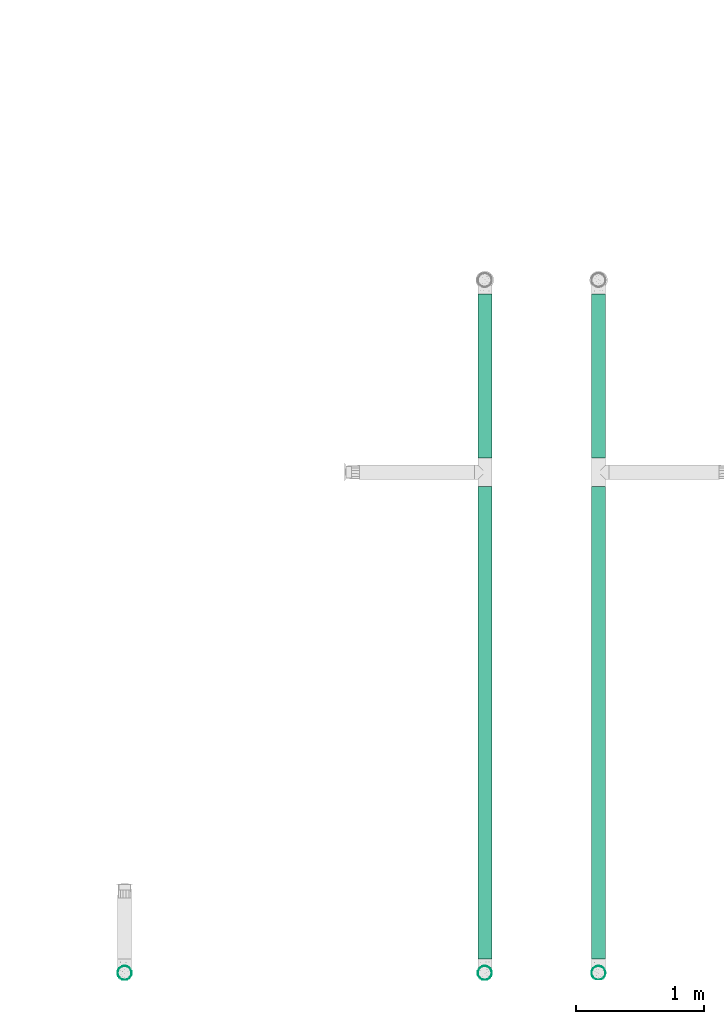
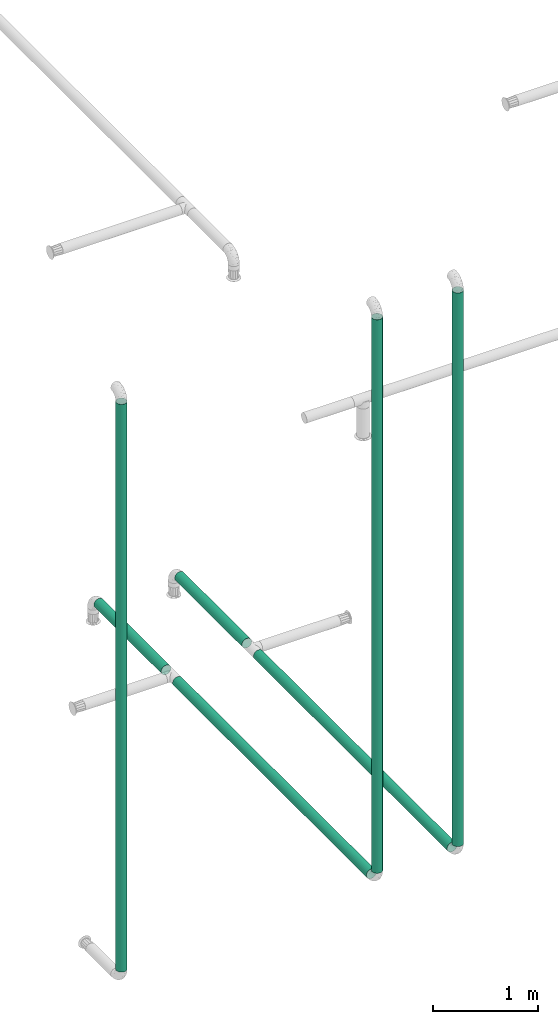
# One storey, part 1 of 123: 7 flow segments.
"""IFC2X3 building model written with IfcOpenShell, lengths in millimetres."""

from ifc_helpers import new_model, entity, si_unit, converted_unit, derived_unit, direction, frame, origin_with_axes, origin_2d_with_axis, place, context, subcontext, project, spatial, hollow_circle, extrude, source, transform, mapped, material, layer, layer_set, layer_usage, type_object, element, save


model = new_model("IFC2X3")

# Units and contexts
model_context = context("Model", 3, precision=1e-05, world=origin_with_axes(), true_north=direction((0.0, 1.0)))
body_context = subcontext(model_context, "Body", "Model", "MODEL_VIEW")
ifc_project = project(units=[si_unit("AREAUNIT", "SQUARE_METRE"), si_unit("VOLUMEUNIT", "CUBIC_METRE", prefix="DECI"), si_unit("TIMEUNIT", "SECOND"), si_unit("THERMODYNAMICTEMPERATUREUNIT", "DEGREE_CELSIUS"), si_unit("PRESSUREUNIT", "PASCAL"), si_unit("MASSUNIT", "GRAM", prefix="KILO"), si_unit("LENGTHUNIT", "METRE", prefix="MILLI"), si_unit("POWERUNIT", "WATT"), si_unit("ELECTRICCURRENTUNIT", "AMPERE"), si_unit("ELECTRICVOLTAGEUNIT", "VOLT"), derived_unit("VOLUMETRICFLOWRATEUNIT", [(si_unit("VOLUMEUNIT", "CUBIC_METRE", prefix="DECI"), 1), (si_unit("TIMEUNIT", "SECOND"), -1)]), derived_unit("LINEARVELOCITYUNIT", [(si_unit("LENGTHUNIT", "METRE"), 1), (si_unit("TIMEUNIT", "SECOND"), -1)]), derived_unit("MASSDENSITYUNIT", [(si_unit("MASSUNIT", "GRAM", prefix="KILO"), 1), (si_unit("VOLUMEUNIT", "CUBIC_METRE"), -1)]), converted_unit("PLANEANGLEUNIT", "DEGREE", entity("IfcRatioMeasure", 0.01745), si_unit("PLANEANGLEUNIT", "RADIAN"), dimensions=[0, 0, 0, 0, 0, 0, 0])], contexts=[model_context])

# Site, building, storey
site_placement = place(None, origin_with_axes())
site = spatial("IfcSite", under=ifc_project, at=site_placement, CompositionType="ELEMENT")
building_placement = place(site_placement, origin_with_axes())
building = spatial("IfcBuilding", under=site, at=building_placement, Name="mc-building", CompositionType="ELEMENT")
storey_placement = place(building_placement, origin_with_axes())
storey = spatial("IfcBuildingStorey", under=building, at=storey_placement, Name="1. Korrus", CompositionType="ELEMENT", Elevation=0.0)

# Flow segments
ifc_material = material(Name="FZ1")
ifc_layer = layer(ifc_material, 0.0)
ifc_layer_set = layer_set([ifc_layer], Name="FZ1")
ifc_layer_usage = layer_usage(ifc_layer_set, "AXIS1", "POSITIVE", 0.0)
duct_segment_type_1 = type_object("IfcDuctSegmentType", Name="Safe", PredefinedType="RIGIDSEGMENT")
shared_shape_1 = source(origin_with_axes(), body_context, "Body", "SweptSolid", [
    extrude(hollow_circle(Radius=55.0, WallThickness=2.0, at=origin_2d_with_axis()), frame((0.0, 0.0, 0.0), z_axis=(1.0, 0.0, 0.0), x_axis=(0.0, 1.0, 0.0)), (0.0, 0.0, 1.0), 6595.0),
])
flow_segment_placement = place(storey_placement, frame((5548.85991, -687.64676, 2410.0), z_axis=(0.0, 1.0, 0.0), x_axis=(0.0, 0.0, 1.0)))
element("IfcFlowSegment", 1, at=flow_segment_placement, inside=storey, type_object=duct_segment_type_1, material=ifc_layer_usage, Name="Safe", context=body_context, shape_type="MappedRepresentation", body=[
    mapped(shared_shape_1, transform((0.0, 0.0, 0.0), scale=1.0)),
])
duct_segment_type_2 = type_object("IfcDuctSegmentType", PredefinedType="RIGIDSEGMENT")
shared_shape_2 = source(origin_with_axes(), body_context, "Body", "SweptSolid", [
    extrude(hollow_circle(Radius=55.0, WallThickness=2.0, at=origin_2d_with_axis()), frame((0.0, 0.0, 0.0), z_axis=(1.0, 0.0, 0.0), x_axis=(0.0, 1.0, 0.0)), (0.0, 0.0, 1.0), 6430.0),
])
for number, where, z_axis, x_axis in (
    (2, (9245.0, -687.64676, 2575.0), (0.0, 1.0, 0.0), (0.0, 0.0, 1.0)),
    (3, (8357.82156, -687.64676, 2575.0), (0.0, 1.0, 0.0), (0.0, 0.0, 1.0)),
):
    element("IfcFlowSegment", number, at=place(storey_placement, frame(where, z_axis=z_axis, x_axis=x_axis)), inside=storey, type_object=duct_segment_type_2, material=ifc_layer_usage, context=body_context, shape_type="MappedRepresentation", body=[
        mapped(shared_shape_2, transform((0.0, 0.0, 0.0), scale=1.0)),
    ])
shared_shape_3 = source(origin_with_axes(), body_context, "Body", "SweptSolid", [
    extrude(hollow_circle(Radius=55.0, WallThickness=2.0, at=origin_2d_with_axis()), frame((0.0, 0.0, 0.0), z_axis=(1.0, 0.0, 0.0), x_axis=(0.0, 1.0, 0.0)), (0.0, 0.0, 1.0), 3685.5),
])
for number, where, z_axis, x_axis in (
    (4, (9245.0, -577.64676, 2465.0), (0.0, 0.0, 1.0), (0.0, 1.0, 0.0)),
    (5, (8357.82156, -577.64676, 2465.0), (0.0, 0.0, 1.0), (0.0, 1.0, 0.0)),
):
    element("IfcFlowSegment", number, at=place(storey_placement, frame(where, z_axis=z_axis, x_axis=x_axis)), inside=storey, type_object=duct_segment_type_2, material=ifc_layer_usage, context=body_context, shape_type="MappedRepresentation", body=[
        mapped(shared_shape_3, transform((0.0, 0.0, 0.0), scale=1.0)),
    ])
shared_shape_4 = source(origin_with_axes(), body_context, "Body", "SweptSolid", [
    extrude(hollow_circle(Radius=55.0, WallThickness=2.0, at=origin_2d_with_axis()), frame((0.0, 0.0, 0.0), z_axis=(1.0, 0.0, 0.0), x_axis=(0.0, 1.0, 0.0)), (0.0, 0.0, 1.0), 1278.0),
])
for number, where, z_axis, x_axis in (
    (6, (9245.0, 3327.8145, 2465.0), (0.0, 0.0, 1.0), (0.0, 1.0, 0.0)),
    (7, (8357.82156, 3327.8145, 2465.0), (0.0, 0.0, 1.0), (0.0, 1.0, 0.0)),
):
    element("IfcFlowSegment", number, at=place(storey_placement, frame(where, z_axis=z_axis, x_axis=x_axis)), inside=storey, type_object=duct_segment_type_2, material=ifc_layer_usage, context=body_context, shape_type="MappedRepresentation", body=[
        mapped(shared_shape_4, transform((0.0, 0.0, 0.0), scale=1.0)),
    ])

save(model, "model.ifc")
